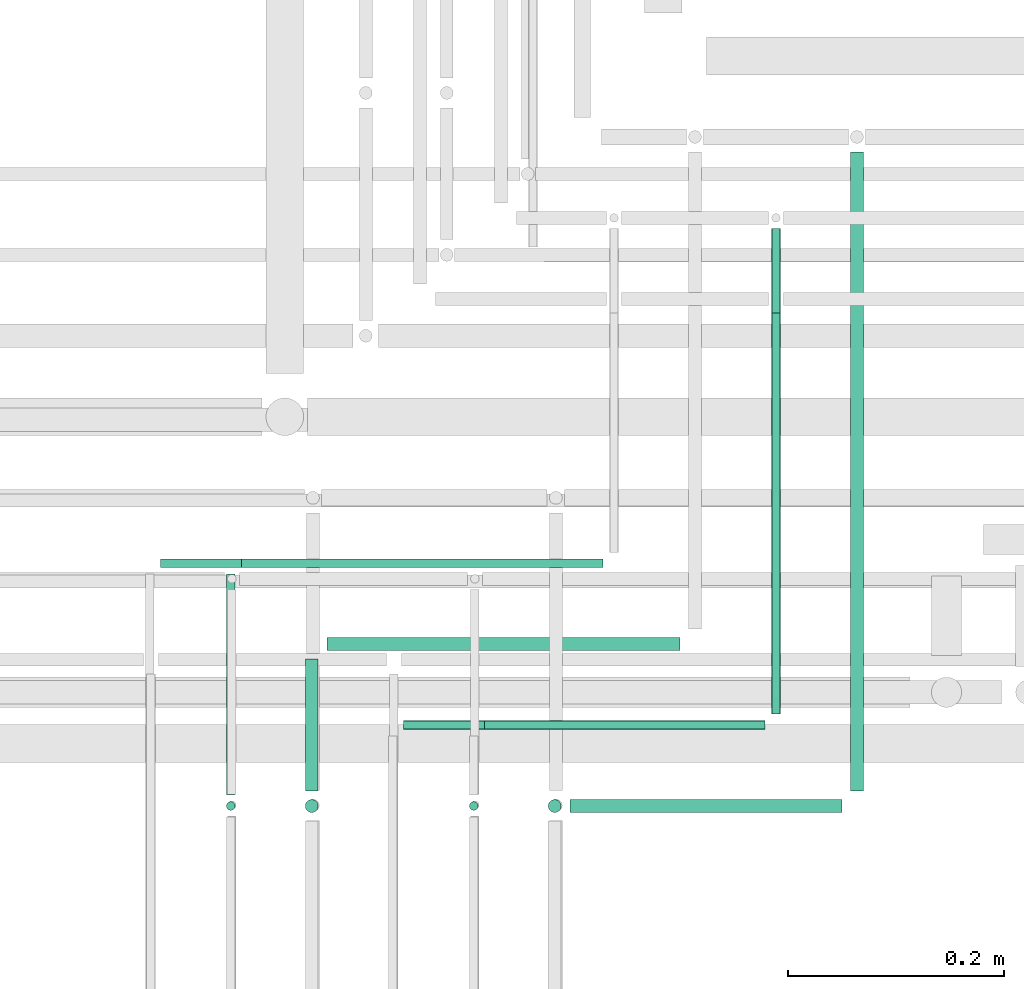
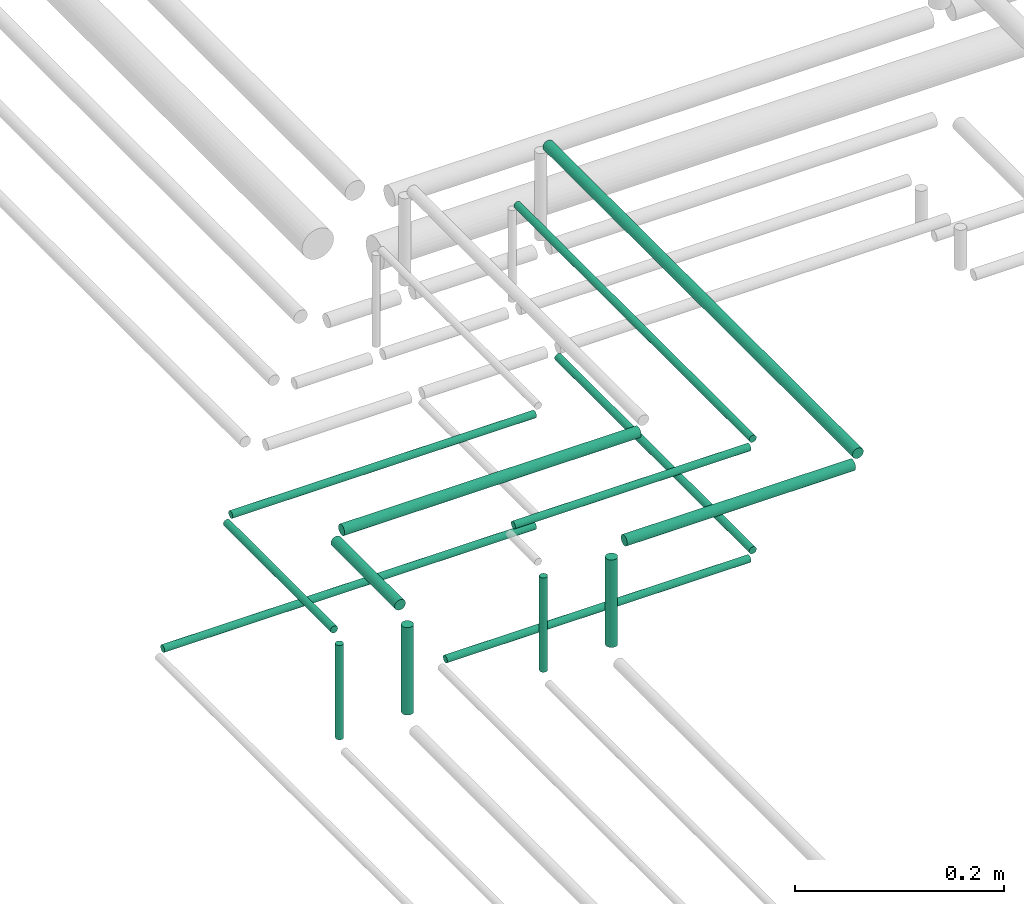
# One storey, part 218 of 331: 15 flow segments.
"""IFC2X3 building model written with IfcOpenShell, lengths in millimetres."""

from ifc_helpers import new_model, entity, si_unit, converted_unit, derived_unit, direction, frame, frame_2d, origin, origin_2d_with_axis, place, context, subcontext, project, spatial, circle, extrude, type_object, element, save


model = new_model("IFC2X3")

# Units and contexts
model_context = context("Model", 3, precision=0.01, world=origin(), true_north=direction((6.12303176911189e-17, 1.0)))
body_context = subcontext(model_context, "Body", "Model", "MODEL_VIEW")
ifc_project = project(units=[si_unit("LENGTHUNIT", "METRE", prefix="MILLI"), si_unit("AREAUNIT", "SQUARE_METRE"), si_unit("VOLUMEUNIT", "CUBIC_METRE"), converted_unit("PLANEANGLEUNIT", "DEGREE", entity("IfcRatioMeasure", 0.0174532925199433), si_unit("PLANEANGLEUNIT", "RADIAN"), dimensions=[0, 0, 0, 0, 0, 0, 0]), si_unit("MASSUNIT", "GRAM", prefix="KILO"), derived_unit("MASSDENSITYUNIT", [(si_unit("MASSUNIT", "GRAM", prefix="KILO"), 1), (si_unit("LENGTHUNIT", "METRE"), -3)]), derived_unit("MOMENTOFINERTIAUNIT", [(si_unit("LENGTHUNIT", "METRE"), 4)]), si_unit("TIMEUNIT", "SECOND"), si_unit("FREQUENCYUNIT", "HERTZ"), si_unit("THERMODYNAMICTEMPERATUREUNIT", "DEGREE_CELSIUS"), derived_unit("THERMALTRANSMITTANCEUNIT", [(si_unit("MASSUNIT", "GRAM", prefix="KILO"), 1), (si_unit("THERMODYNAMICTEMPERATUREUNIT", "KELVIN"), -1), (si_unit("TIMEUNIT", "SECOND"), -3)]), derived_unit("VOLUMETRICFLOWRATEUNIT", [(si_unit("LENGTHUNIT", "METRE"), 3), (si_unit("TIMEUNIT", "SECOND"), -1)]), derived_unit("MASSFLOWRATEUNIT", [(si_unit("MASSUNIT", "GRAM", prefix="KILO"), 1), (si_unit("TIMEUNIT", "SECOND"), -1)]), derived_unit("ROTATIONALFREQUENCYUNIT", [(si_unit("TIMEUNIT", "SECOND"), -1)]), si_unit("ELECTRICCURRENTUNIT", "AMPERE"), si_unit("ELECTRICVOLTAGEUNIT", "VOLT"), si_unit("POWERUNIT", "WATT"), si_unit("FORCEUNIT", "NEWTON", prefix="KILO"), si_unit("ILLUMINANCEUNIT", "LUX"), si_unit("LUMINOUSFLUXUNIT", "LUMEN"), si_unit("LUMINOUSINTENSITYUNIT", "CANDELA"), derived_unit("USERDEFINED", [(si_unit("MASSUNIT", "GRAM", prefix="KILO"), -1), (si_unit("LENGTHUNIT", "METRE"), -2), (si_unit("TIMEUNIT", "SECOND"), 3), (si_unit("LUMINOUSFLUXUNIT", "LUMEN"), 1)]), derived_unit("LINEARVELOCITYUNIT", [(si_unit("LENGTHUNIT", "METRE"), 1), (si_unit("TIMEUNIT", "SECOND"), -1)]), si_unit("PRESSUREUNIT", "PASCAL"), derived_unit("USERDEFINED", [(si_unit("LENGTHUNIT", "METRE"), -2), (si_unit("MASSUNIT", "GRAM", prefix="KILO"), 1), (si_unit("TIMEUNIT", "SECOND"), -2)]), derived_unit("LINEARFORCEUNIT", [(si_unit("MASSUNIT", "GRAM", prefix="KILO"), 1), (si_unit("LENGTHUNIT", "METRE"), 1), (si_unit("TIMEUNIT", "SECOND"), -2), (si_unit("LENGTHUNIT", "METRE"), -1)]), derived_unit("PLANARFORCEUNIT", [(si_unit("MASSUNIT", "GRAM", prefix="KILO"), 1), (si_unit("LENGTHUNIT", "METRE"), 1), (si_unit("TIMEUNIT", "SECOND"), -2), (si_unit("LENGTHUNIT", "METRE"), -2)])], contexts=[model_context])

# Site, building, storey
site_placement = place(None, frame((0.0, -0.00077364408347762, 0.0)))
site = spatial("IfcSite", under=ifc_project, at=site_placement, CompositionType="ELEMENT")
building_placement = place(site_placement, origin())
building = spatial("IfcBuilding", under=site, at=building_placement, CompositionType="ELEMENT")
storey_placement = place(building_placement, origin())
storey = spatial("IfcBuildingStorey", under=building, at=storey_placement, CompositionType="ELEMENT", Elevation=0.0)

# Flow segments
pipe_segment_type = type_object("IfcPipeSegmentType", PredefinedType="NOTDEFINED")
flow_segment_1_placement = place(storey_placement, frame((61939.4468045266, 8084.55353441889, 18460.0)))
element("IfcFlowSegment", 1, at=flow_segment_1_placement, inside=storey, type_object=pipe_segment_type, context=body_context, shape_type="SweptSolid", body=[
    extrude(circle(Radius=4.0, at=origin_2d_with_axis()), frame((5.59527223591499, 5.59527223591607, 0.0)), (0.0, 0.0, 1.0), 110.00000000001),
])
flow_segment_2_placement = place(storey_placement, frame((61939.4468045265, 8100.1488066548, 18574.4047277641)))
element("IfcFlowSegment", 2, at=flow_segment_2_placement, inside=storey, type_object=pipe_segment_type, context=body_context, shape_type="SweptSolid", body=[
    extrude(circle(Radius=4.0, at=frame_2d((3.46517481375486e-11, 0.0), x_axis=(1.0, 0.0))), frame((5.59527223594964, 0.0, 5.59527223591499), z_axis=(0.0, 1.0, 0.0), x_axis=(-1.0, 0.0, 0.0)), (0.0, 0.0, 1.0), 205.000000000075),
])
flow_segment_3_placement = place(storey_placement, frame((62012.4468045266, 8082.55353441898, 18464.0)))
element("IfcFlowSegment", 3, at=flow_segment_3_placement, inside=storey, type_object=pipe_segment_type, context=body_context, shape_type="SweptSolid", body=[
    extrude(circle(Radius=6.0, at=frame_2d((0.0, -1.08286712929839e-12), x_axis=(1.0, 0.0))), frame((7.59527223591454, 7.59527223591454, 0.0), z_axis=(0.0, 0.0, 1.0), x_axis=(-1.0, 0.0, 0.0)), (0.0, 0.0, 1.0), 102.000000000014),
])
flow_segment_4_placement = place(storey_placement, frame((62012.4468045266, 8104.14880665488, 18572.4047277633)))
element("IfcFlowSegment", 4, at=flow_segment_4_placement, inside=storey, type_object=pipe_segment_type, context=body_context, shape_type="SweptSolid", body=[
    extrude(circle(Radius=6.0, at=frame_2d((-8.66293703438714e-12, 3.60800375296905e-27), x_axis=(1.0, 0.0))), frame((7.5952722359232, 0.0, 7.5952722359167), z_axis=(0.0, 1.0, 0.0), x_axis=(-1.0, 0.0, 0.0)), (0.0, 0.0, 1.0), 121.999999999997),
])
flow_segment_5_placement = place(storey_placement, frame((62164.4468045266, 8084.55353441898, 18460.0)))
element("IfcFlowSegment", 5, at=flow_segment_5_placement, inside=storey, type_object=pipe_segment_type, context=body_context, shape_type="SweptSolid", body=[
    extrude(circle(Radius=4.0, at=frame_2d((0.0, -1.08286712929839e-12), x_axis=(1.0, 0.0))), frame((5.59527223591499, 5.59527223591499, 0.0), z_axis=(0.0, 0.0, 1.0), x_axis=(-1.0, 0.0, 0.0)), (0.0, 0.0, 1.0), 110.000000000036),
])
flow_segment_6_placement = place(storey_placement, frame((62237.4468045266, 8082.55353441898, 18464.0)))
element("IfcFlowSegment", 6, at=flow_segment_6_placement, inside=storey, type_object=pipe_segment_type, context=body_context, shape_type="SweptSolid", body=[
    extrude(circle(Radius=6.0, at=frame_2d((0.0, -1.08286712929839e-12), x_axis=(1.0, 0.0))), frame((7.59527223591454, 7.59527223591454, 0.0), z_axis=(0.0, 0.0, 1.0), x_axis=(-1.0, 0.0, 0.0)), (0.0, 0.0, 1.0), 102.000000000055),
])
flow_segment_7_placement = place(building_placement, frame((62259.0420767625, 8082.55353441896, 18572.4047277641)))
element("IfcFlowSegment", 7, at=flow_segment_7_placement, inside=storey, type_object=pipe_segment_type, context=body_context, shape_type="SweptSolid", body=[
    extrude(circle(Radius=6.0, at=origin_2d_with_axis()), frame((0.0, 7.59527223591778, 7.5952722359167), z_axis=(1.0, 0.0, 0.0), x_axis=(0.0, -1.0, 0.0)), (0.0, 0.0, 1.0), 251.966726740561),
])
flow_segment_8_placement = place(building_placement, frame((62517.4135312672, 8104.14880665487, 18572.4047277633)))
element("IfcFlowSegment", 8, at=flow_segment_8_placement, inside=storey, type_object=pipe_segment_type, context=body_context, shape_type="SweptSolid", body=[
    extrude(circle(Radius=6.0, at=frame_2d((0.0, 2.16573425859679e-12), x_axis=(1.0, 0.0))), frame((7.59527223591454, 0.0, 7.59527223591454), z_axis=(0.0, 1.0, 0.0), x_axis=(-1.0, 0.0, 0.0)), (0.0, 0.0, 1.0), 591.661927827566),
])
flow_segment_9_placement = place(building_placement, frame((62180.0420767625, 8159.55353441895, 18574.4047277633)))
element("IfcFlowSegment", 9, at=flow_segment_9_placement, inside=storey, type_object=pipe_segment_type, context=body_context, shape_type="SweptSolid", body=[
    extrude(circle(Radius=4.0, at=origin_2d_with_axis()), frame((0.0, 5.59527223592257, 5.59527223591499), z_axis=(1.0, 0.0, 0.0), x_axis=(0.0, -1.0, 0.0)), (0.0, 0.0, 1.0), 259.966726740567),
])
flow_segment_10_placement = place(building_placement, frame((62444.4135312672, 8175.14880665487, 18574.4047277633)))
element("IfcFlowSegment", 10, at=flow_segment_10_placement, inside=storey, type_object=pipe_segment_type, context=body_context, shape_type="SweptSolid", body=[
    extrude(circle(Radius=4.0, at=origin_2d_with_axis()), frame((5.59527223591499, 0.0, 5.59527223591499), z_axis=(0.0, 1.0, 0.0), x_axis=(-1.0, 0.0, 0.0)), (0.0, 0.0, 1.0), 449.661927827576),
])
flow_segment_11_placement = place(building_placement, frame((62105.0420767625, 8159.55353441895, 18444.4047277641)))
element("IfcFlowSegment", 11, at=flow_segment_11_placement, inside=storey, type_object=pipe_segment_type, context=body_context, shape_type="SweptSolid", body=[
    extrude(circle(Radius=4.0, at=origin_2d_with_axis()), frame((0.0, 5.59527223592257, 5.59527223591499), z_axis=(1.0, 0.0, 0.0), x_axis=(0.0, -1.0, 0.0)), (0.0, 0.0, 1.0), 334.96672674055),
])
flow_segment_12_placement = place(building_placement, frame((62444.4135312672, 8175.14880665487, 18444.4047277641)))
element("IfcFlowSegment", 12, at=flow_segment_12_placement, inside=storey, type_object=pipe_segment_type, context=body_context, shape_type="SweptSolid", body=[
    extrude(circle(Radius=4.0, at=origin_2d_with_axis()), frame((5.59527223591499, 0.0, 5.59527223591499), z_axis=(0.0, 1.0, 0.0), x_axis=(-1.0, 0.0, 0.0)), (0.0, 0.0, 1.0), 371.661927827562),
])
flow_segment_13_placement = place(building_placement, frame((62034.0420767625, 8232.55353441896, 18572.4047277633)))
element("IfcFlowSegment", 13, at=flow_segment_13_placement, inside=storey, type_object=pipe_segment_type, context=body_context, shape_type="SweptSolid", body=[
    extrude(circle(Radius=6.0, at=frame_2d((0.0, -2.16573425859679e-12), x_axis=(1.0, 0.0))), frame((0.0, 7.59527223592212, 7.59527223591454), z_axis=(1.0, 0.0, 0.0), x_axis=(0.0, -1.0, 0.0)), (0.0, 0.0, 1.0), 326.966726740543),
])
flow_segment_14_placement = place(building_placement, frame((61955.0420767625, 8309.55353441896, 18574.4047277641)))
element("IfcFlowSegment", 14, at=flow_segment_14_placement, inside=storey, type_object=pipe_segment_type, context=body_context, shape_type="SweptSolid", body=[
    extrude(circle(Radius=4.0, at=origin_2d_with_axis()), frame((0.0, 5.59527223592365, 5.59527223591499), z_axis=(1.0, 0.0, 0.0), x_axis=(0.0, -1.0, 0.0)), (0.0, 0.0, 1.0), 334.966726740628),
])
flow_segment_15_placement = place(building_placement, frame((61880.0420767625, 8309.55353441896, 18444.4047277641)))
element("IfcFlowSegment", 15, at=flow_segment_15_placement, inside=storey, type_object=pipe_segment_type, context=body_context, shape_type="SweptSolid", body=[
    extrude(circle(Radius=4.0, at=frame_2d((-1.08286712929839e-12, 0.0), x_axis=(1.0, 0.0))), frame((0.0, 5.59527223592149, 5.59527223591499), z_axis=(1.0, 0.0, 0.0), x_axis=(0.0, -1.0, 0.0)), (0.0, 0.0, 1.0), 409.966726740559),
])

save(model, "model.ifc")
